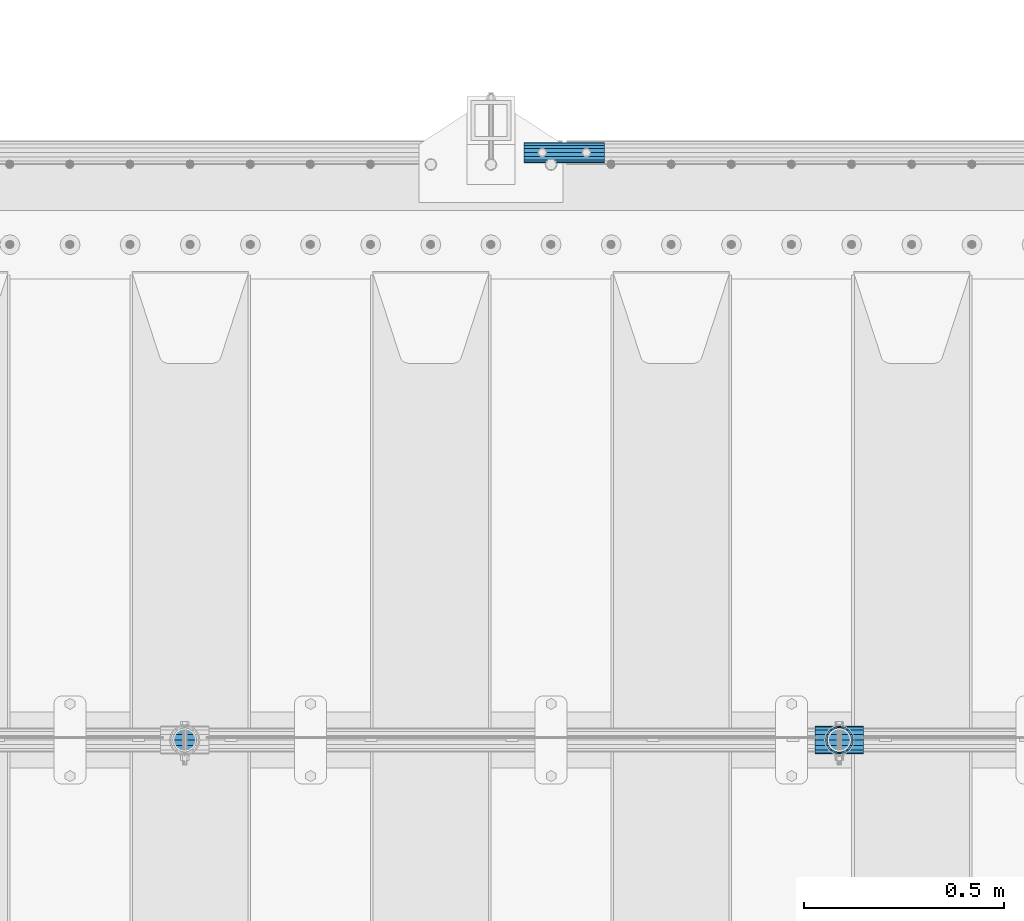
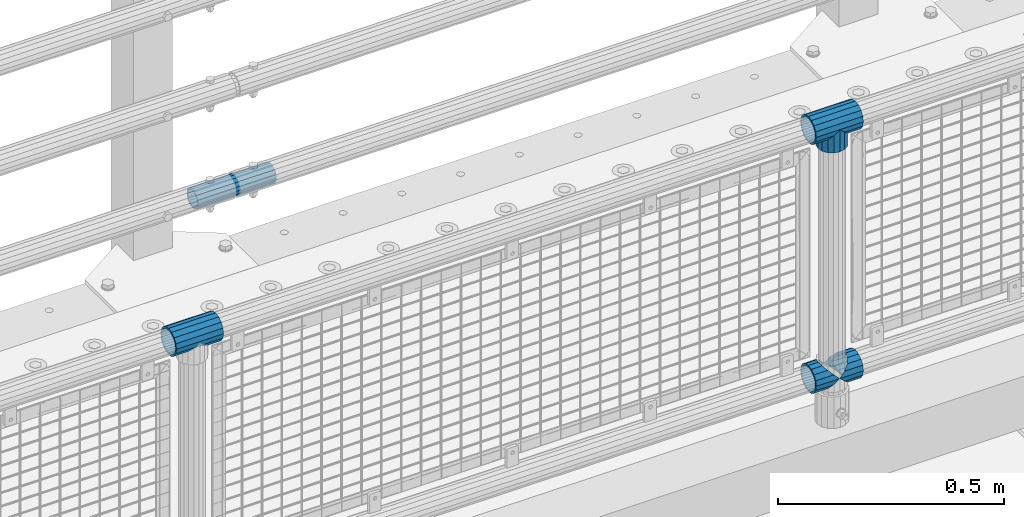
# One storey, part 167 of 270: 6 beams.
"""IFC2X3 building model written with IfcOpenShell, lengths in millimetres."""

from ifc_helpers import new_model, si_unit, frame, origin_with_axes, place, context, subcontext, project, spatial, faceted_brep, material, type_object, element, save


model = new_model("IFC2X3")

# Units and contexts
model_context = context("Model", 3, precision=1e-05, world=origin_with_axes())
body_context = subcontext(model_context, "Body", "Model", "MODEL_VIEW")
ifc_project = project(units=[si_unit("LENGTHUNIT", "METRE", prefix="MILLI"), si_unit("AREAUNIT", "SQUARE_METRE"), si_unit("VOLUMEUNIT", "CUBIC_METRE"), si_unit("MASSUNIT", "GRAM", prefix="KILO"), si_unit("TIMEUNIT", "SECOND"), si_unit("PLANEANGLEUNIT", "RADIAN"), si_unit("SOLIDANGLEUNIT", "STERADIAN"), si_unit("THERMODYNAMICTEMPERATUREUNIT", "DEGREE_CELSIUS"), si_unit("LUMINOUSINTENSITYUNIT", "LUMEN")], contexts=[model_context])

# Site, building, storey
site_placement = place(None, origin_with_axes())
site = spatial("IfcSite", under=ifc_project, at=site_placement, CompositionType="ELEMENT")
building_placement = place(site_placement, origin_with_axes())
building = spatial("IfcBuilding", under=site, at=building_placement, Name="Standard", CompositionType="ELEMENT")
storey_placement = place(building_placement, origin_with_axes())
storey = spatial("IfcBuildingStorey", under=building, at=storey_placement, Name="Undefined", CompositionType="ELEMENT", Elevation=0.0)

# Beams
ifc_material_1 = material(Name="Misc_Undefined")
beam_type_1 = type_object("IfcBeamType", PredefinedType="NOTDEFINED")
beam_1_placement = place(storey_placement, frame((10358.85, -16335.5, 298.17), z_axis=(0.0, 1.0, 0.0), x_axis=(1.0, 0.0, 0.0)))
element("IfcBeam", 1, at=beam_1_placement, inside=storey, type_object=beam_type_1, material=ifc_material_1, context=body_context, shape_type="Brep", body=[
    faceted_brep([(60.1499999999978, 0.0, -35.1499999999996), (46.698677352364, 13.4513226476329, -32.4743655677721), (46.698677352364, -13.4513226476329, -32.4743655677721), (33.0273231408937, 21.4606908090117, 21.4606908090118), (27.6756344322275, 26.8123795176776, 13.4513226476338), (27.6756344322275, 32.4743655677717, 13.4513226476338), (35.2951966412911, 24.8548033587072, 24.8548033587067), (35.2951966412911, 16.3810424080045, 24.8548033587067), (27.310256188277, 28.0397438117175, 11.6144421722802), (24.9999999999964, 30.35, 0.0), (24.9999999999964, 35.15, 0.0), (27.6756344322275, 26.8123795176775, -13.4513226476338), (27.6756344322275, 32.4743655677717, -13.4513226476338), (27.310256188277, 28.0397438117175, -11.6144421722802), (35.2951966412911, 16.3810424080045, -24.8548033587067), (35.2951966412911, 24.8548033587072, -24.8548033587067), (33.0273231408937, 21.4606908090117, -21.4606908090118), (40.0617968770166, 11.6144421722805, -28.0397438117179), (43.519339601633, 0.0, -30.3500000000004), (40.0617968770166, -11.6144421722805, -28.0397438117179), (35.2951966412911, -16.3810424080045, -24.8548033587067), (35.2951966412911, -24.8548033587072, -24.8548033587067), (33.0273231408937, -21.4606908090117, -21.4606908090118), (27.6756344322275, -26.8123795176776, -13.4513226476338), (27.6756344322275, -32.4743655677717, -13.4513226476338), (27.310256188277, -28.0397438117175, -11.6144421722802), (24.9999999999964, -30.35, 0.0), (24.9999999999964, -35.15, 0.0), (27.310256188277, -28.0397438117175, 11.6144421722802), (27.6756344322275, -26.8123795176775, 13.4513226476338), (27.6756344322275, -32.4743655677717, 13.4513226476338), (33.0273231408937, -21.4606908090117, 21.4606908090118), (35.2951966412911, -16.3810424080078, 24.8548033587067), (35.2951966412911, -24.8548033587072, 24.8548033587067), (60.1499999999978, 0.0, 35.1499999999996), (46.698677352364, -13.4513226476329, 32.4743655677721), (46.698677352364, 13.4513226476329, 32.4743655677721), (40.061796877013, -11.6144421722805, 28.0397438117179), (43.5193396016293, 0.0, 30.3500000000004), (40.061796877013, 11.6144421722805, 28.0397438117179), (0.0, -32.4743655677721, -13.4513226476338), (0.0, -24.8548033587067, -24.8548033587067), (0.0, -13.4513226476338, -32.4743655677703), (0.0, 0.0, -35.1499999999996), (0.0, 13.4513226476338, -32.4743655677703), (0.0, 24.8548033587067, -24.8548033587067), (0.0, 32.4743655677721, -13.4513226476338), (0.0, 35.1499999999996, 0.0), (0.0, 32.4743655677721, 13.4513226476338), (0.0, 24.8548033587067, 24.8548033587067), (0.0, 13.4513226476338, 32.4743655677703), (0.0, 0.0, 35.1499999999996), (0.0, -32.4743655677721, 13.4513226476338), (0.0, -35.1499999999996, 0.0), (0.0, -24.8548033587067, 24.8548033587067), (0.0, -13.4513226476338, 32.4743655677703), (0.0, -28.0397438117179, -11.614442172282), (0.0, -21.4606908090118, -21.46069080901), (0.0, -11.6144421722802, -28.0397438117179), (0.0, 0.0, -30.3499999999985), (0.0, 11.6144421722802, -28.0397438117179), (0.0, 21.4606908090118, -21.46069080901), (0.0, 28.0397438117179, -11.614442172282), (0.0, 30.3500000000004, 0.0), (0.0, 28.0397438117179, 11.614442172282), (0.0, 21.4606908090118, 21.46069080901), (0.0, 11.6144421722802, 28.0397438117179), (0.0, 0.0, 30.3499999999985), (0.0, -11.6144421722802, 28.0397438117179), (0.0, -21.4606908090118, 21.46069080901), (0.0, -28.0397438117179, 11.614442172282), (0.0, -30.3500000000004, 0.0)], [[[0, 1, 2]], [[3, 4, 5, 6, 7]], [[8, 9, 10, 5, 4]], [[11, 12, 10, 9, 13]], [[14, 15, 12, 11, 16]], [[2, 1, 15, 14, 17, 18, 19, 20, 21]], [[21, 20, 22, 23, 24]], [[24, 23, 25, 26, 27]], [[27, 26, 28, 29, 30]], [[30, 29, 31, 32, 33]], [[34, 35, 36]], [[33, 32, 37, 38, 39, 7, 6, 36, 35]], [[40, 41, 21, 24]], [[41, 42, 2, 21]], [[42, 43, 0, 2]], [[43, 44, 1, 0]], [[44, 45, 15, 1]], [[45, 46, 12, 15]], [[46, 47, 10, 12]], [[47, 48, 5, 10]], [[48, 49, 6, 5]], [[49, 50, 36, 6]], [[50, 51, 34, 36]], [[52, 53, 27, 30]], [[54, 52, 30, 33]], [[55, 54, 33, 35]], [[51, 55, 35, 34]], [[53, 40, 24, 27]], [[52, 54, 55, 51, 50, 49, 48, 47, 46, 45, 44, 43, 42, 41, 40, 53], [56, 57, 58, 59, 60, 61, 62, 63, 64, 65, 66, 67, 68, 69, 70, 71]], [[68, 67, 38, 37]], [[31, 69, 68, 37, 32]], [[28, 70, 69, 31, 29]], [[71, 70, 28, 26]], [[56, 71, 26, 25]], [[57, 56, 25, 23, 22]], [[58, 57, 22, 20, 19]], [[59, 58, 19, 18]], [[60, 59, 18, 17]], [[16, 61, 60, 17, 14]], [[13, 62, 61, 16, 11]], [[63, 62, 13, 9]], [[64, 63, 9, 8]], [[65, 64, 8, 4, 3]], [[66, 65, 3, 7, 39]], [[67, 66, 39, 38]]]),
])
beam_2_placement = place(storey_placement, frame((10419.0, -16335.5, 298.17), z_axis=(0.0, 1.0, 0.0), x_axis=(1.0, 0.0, 0.0)))
element("IfcBeam", 2, at=beam_2_placement, inside=storey, type_object=beam_type_1, material=ifc_material_1, context=body_context, shape_type="Brep", body=[
    faceted_brep([(13.4513226476338, 13.4513226476329, 32.4743655677721), (13.4513226476338, -13.4513226476329, 32.4743655677721), (0.0, 0.0, 35.1499999999996), (27.1226768591041, -21.4606908090117, -21.4606908090118), (24.8548033587067, -16.3810424080045, -24.8548033587067), (24.8548033587067, -24.8548033587072, -24.8548033587067), (32.4743655677703, -32.4743655677717, -13.4513226476338), (32.4743655677703, -26.8123795176776, -13.4513226476338), (0.0, 0.0, -35.1499999999996), (13.4513226476338, -13.4513226476329, -32.4743655677721), (13.4513226476338, 13.4513226476329, -32.4743655677721), (20.0882031229849, -11.6144421722805, -28.0397438117179), (16.6306603983721, 0.0, -30.3500000000004), (20.0882031229849, 11.6144421722805, -28.0397438117179), (24.8548033587067, 16.3810424080045, -24.8548033587067), (24.8548033587067, 24.8548033587072, -24.8548033587067), (27.1226768591041, 21.4606908090117, -21.4606908090118), (32.4743655677703, 26.8123795176775, -13.4513226476338), (32.4743655677703, 32.4743655677717, -13.4513226476338), (32.8397438117172, 28.0397438117175, -11.6144421722802), (35.1500000000015, 30.35, 0.0), (35.1500000000015, 35.1500000000003, 0.0), (32.8397438117208, 28.0397438117175, 11.6144421722802), (32.4743655677703, 26.8123795176776, 13.4513226476338), (32.4743655677703, 32.4743655677717, 13.4513226476338), (27.1226768591041, 21.4606908090117, 21.4606908090118), (24.8548033587067, 16.3810424080045, 24.8548033587067), (24.8548033587067, 24.8548033587072, 24.8548033587067), (20.0882031229812, 11.6144421722805, 28.0397438117179), (16.6306603983612, 0.0, 30.3500000000004), (20.0882031229812, -11.6144421722805, 28.0397438117179), (24.8548033587067, -16.3810424080045, 24.8548033587067), (24.8548033587067, -24.8548033587072, 24.8548033587067), (32.4743655677703, -26.8123795176775, 13.4513226476338), (32.4743655677703, -32.4743655677717, 13.4513226476338), (27.1226768591041, -21.4606908090117, 21.4606908090118), (35.1500000000015, -30.35, 0.0), (35.1500000000015, -35.15, 0.0), (32.8397438117208, -28.0397438117175, 11.6144421722802), (32.8397438117172, -28.0397438117175, -11.6144421722802), (60.1500000000015, -24.8548033587072, -24.8548033587067), (60.1500000000015, -32.4743655677717, -13.4513226476338), (60.1500000000015, -13.4513226476329, -32.4743655677721), (60.1499999999978, 0.0, -35.1499999999996), (60.1500000000015, 13.4513226476329, -32.4743655677721), (60.1500000000015, 24.8548033587072, -24.8548033587067), (60.1500000000015, 32.4743655677717, -13.4513226476338), (60.1500000000015, 35.15, 0.0), (60.1500000000015, 32.4743655677717, 13.4513226476338), (60.1500000000015, 24.8548033587072, 24.8548033587067), (60.1500000000015, 13.4513226476329, 32.4743655677721), (60.1499999999978, 0.0, 35.1499999999996), (60.1500000000015, -13.4513226476329, 32.4743655677721), (60.1500000000015, -24.8548033587072, 24.8548033587067), (60.1500000000015, -32.4743655677717, 13.4513226476338), (60.1500000000015, -35.15, 0.0), (60.1500000000015, -21.4606908090117, 21.4606908090118), (60.1500000000015, -11.6144421722805, 28.0397438117179), (60.1500000000015, 0.0, 30.3500000000004), (60.1500000000015, 11.6144421722805, 28.0397438117179), (60.1500000000015, 21.4606908090117, 21.4606908090118), (60.1500000000015, 28.0397438117175, 11.6144421722802), (60.1500000000015, 30.35, 0.0), (60.1500000000015, 28.0397438117175, -11.6144421722802), (60.1500000000015, 21.4606908090117, -21.4606908090118), (60.1500000000015, 11.6144421722805, -28.0397438117179), (60.1500000000015, 0.0, -30.3500000000004), (60.1500000000015, -11.6144421722805, -28.0397438117179), (60.1500000000015, -21.4606908090117, -21.4606908090118), (60.1500000000015, -28.0397438117175, -11.6144421722802), (60.1500000000015, -30.35, 0.0), (60.1500000000015, -28.0397438117175, 11.6144421722802)], [[[0, 1, 2]], [[3, 4, 5, 6, 7]], [[8, 9, 10]], [[10, 9, 5, 4, 11, 12, 13, 14, 15]], [[15, 14, 16, 17, 18]], [[18, 17, 19, 20, 21]], [[21, 20, 22, 23, 24]], [[24, 23, 25, 26, 27]], [[27, 26, 28, 29, 30, 31, 32, 1, 0]], [[33, 34, 32, 31, 35]], [[36, 37, 34, 33, 38]], [[39, 7, 6, 37, 36]], [[40, 41, 6, 5]], [[42, 40, 5, 9]], [[43, 42, 9, 8]], [[44, 43, 8, 10]], [[45, 44, 10, 15]], [[46, 45, 15, 18]], [[47, 46, 18, 21]], [[48, 47, 21, 24]], [[49, 48, 24, 27]], [[50, 49, 27, 0]], [[51, 50, 0, 2]], [[52, 51, 2, 1]], [[53, 52, 1, 32]], [[54, 53, 32, 34]], [[55, 54, 34, 37]], [[41, 55, 37, 6]], [[40, 42, 43, 44, 45, 46, 47, 48, 49, 50, 51, 52, 53, 54, 55, 41], [56, 57, 58, 59, 60, 61, 62, 63, 64, 65, 66, 67, 68, 69, 70, 71]], [[71, 70, 36, 38]], [[35, 56, 71, 38, 33]], [[30, 57, 56, 35, 31]], [[58, 57, 30, 29]], [[59, 58, 29, 28]], [[60, 59, 28, 26, 25]], [[61, 60, 25, 23, 22]], [[62, 61, 22, 20]], [[63, 62, 20, 19]], [[16, 64, 63, 19, 17]], [[13, 65, 64, 16, 14]], [[66, 65, 13, 12]], [[67, 66, 12, 11]], [[68, 67, 11, 4, 3]], [[69, 68, 3, 7, 39]], [[70, 69, 39, 36]]]),
])
beam_3_placement = place(storey_placement, frame((8725.85, -16335.5, 969.849999999999), z_axis=(0.0, 0.0, 1.0), x_axis=(1.0, 0.0, 0.0)))
element("IfcBeam", 3, at=beam_3_placement, inside=storey, type_object=beam_type_1, material=ifc_material_1, context=body_context, shape_type="Brep", body=[
    faceted_brep([(88.1897438117176, -11.6144421722802, -28.0397438117176), (88.1897438117176, -11.6144421722802, -32.839743811718), (86.9623795176758, -13.4513226476338, -32.4743655677718), (81.6106908090119, -21.4606908090118, -27.1226768591079), (81.6106908090119, -21.4606908090118, -21.4606908090117), (76.5310424080044, -24.8548033587067, -24.8548033587072), (71.7644421722807, -28.0397438117179, -20.0882031229829), (71.7644421722807, -28.0397438117179, -11.6144421722805), (60.1500000000001, -30.3500000000004, -16.6306603983638), (60.1500000000015, -30.35, 0.0), (48.5355578277195, -28.0397438117179, -20.0882031229829), (48.5355578277195, -28.0397438117179, -11.6144421722805), (43.7689575919958, -24.8548033587067, -24.8548033587072), (38.6893091909883, -21.4606908090118, -27.1226768591079), (38.6893091909883, -21.4606908090118, -21.4606908090117), (33.3376204823235, -13.4513226476338, -32.4743655677718), (32.1102561882826, -11.6144421722802, -32.839743811718), (32.1102561882826, -11.6144421722802, -28.0397438117176), (29.8000000000002, 0.0, -35.15), (29.8000000000002, 0.0, -30.35), (32.1102561882826, 11.6144421722802, -32.839743811718), (32.1102561882826, 11.6144421722802, -28.0397438117176), (33.3376204823244, 13.4513226476338, -32.4743655677718), (38.6893091909883, 21.4606908090118, -27.1226768591056), (38.6893091909883, 21.4606908090118, -21.4606908090117), (43.7689575919958, 24.8548033587067, -24.8548033587072), (48.5355578277195, 28.0397438117179, -20.0882031229829), (48.5355578277195, 28.0397438117179, -11.6144421722805), (60.1500000000001, 30.3500000000004, -16.6306603983638), (60.1500000000015, 30.35, 0.0), (71.7644421722807, 28.0397438117179, -20.0882031229829), (71.7644421722807, 28.0397438117179, -11.6144421722805), (76.5310424080044, 24.8548033587067, -24.8548033587072), (81.6106908090119, 21.4606908090118, -27.1226768591056), (81.6106908090119, 21.4606908090118, -21.4606908090117), (86.9623795176776, 13.4513226476338, -32.4743655677718), (88.1897438117176, 11.6144421722802, -32.839743811718), (88.1897438117176, 11.6144421722802, -28.0397438117176), (90.5, 0.0, -35.15), (90.5, 0.0, -30.35), (0.0, -21.4606908090118, -21.46069080901), (0.0, -28.0397438117179, -11.614442172282), (0.0, -11.6144421722802, -28.0397438117179), (0.0, 0.0, -30.3499999999985), (0.0, 11.6144421722802, -28.0397438117179), (0.0, 21.4606908090118, -21.46069080901), (0.0, 28.0397438117179, -11.614442172282), (0.0, 30.3500000000004, 0.0), (0.0, 32.4743655677721, -13.4513226476338), (0.0, 35.1499999999996, 0.0), (120.3, 35.1499999999996, 0.0), (120.3, 32.4743655677721, -13.4513226476329), (0.0, 32.4743655677721, 13.4513226476338), (120.3, 32.4743655677721, 13.4513226476329), (0.0, 24.8548033587067, 24.8548033587067), (120.3, 24.8548033587067, 24.8548033587072), (0.0, 13.4513226476338, 32.4743655677703), (120.3, 13.4513226476338, 32.4743655677718), (0.0, 0.0, 35.1499999999996), (120.3, 0.0, 35.15), (0.0, -13.4513226476338, 32.4743655677703), (120.3, -13.4513226476338, 32.4743655677718), (0.0, -24.8548033587067, 24.8548033587067), (120.3, -24.8548033587067, 24.8548033587072), (0.0, -32.4743655677721, 13.4513226476338), (120.3, -32.4743655677721, 13.4513226476329), (0.0, -35.1499999999996, 0.0), (120.3, -35.1499999999996, 0.0), (0.0, -32.4743655677721, -13.4513226476338), (120.3, -32.4743655677721, -13.4513226476329), (0.0, 24.8548033587067, -24.8548033587067), (0.0, 13.4513226476338, -32.4743655677703), (0.0, 0.0, -35.1499999999996), (0.0, -13.4513226476338, -32.4743655677703), (0.0, -24.8548033587067, -24.8548033587067), (0.0, 28.0397438117179, 11.614442172282), (0.0, 21.4606908090118, 21.46069080901), (0.0, 11.6144421722802, 28.0397438117179), (0.0, 0.0, 30.3499999999985), (0.0, -11.6144421722802, 28.0397438117179), (0.0, -21.4606908090118, 21.46069080901), (0.0, -28.0397438117179, 11.614442172282), (0.0, -30.3500000000004, 0.0), (120.3, -30.3500000000004, 0.0), (120.3, -28.0397438117179, -11.6144421722805), (120.3, -21.4606908090118, -21.4606908090117), (120.3, -11.6144421722802, -28.0397438117176), (120.3, 0.0, -30.35), (120.3, 21.4606908090118, -21.4606908090117), (120.3, 28.0397438117179, -11.6144421722805), (120.3, 11.6144421722802, -28.0397438117176), (120.3, 30.3500000000004, 0.0), (120.3, 28.0397438117179, 11.6144421722805), (120.3, 21.4606908090118, 21.4606908090117), (120.3, 11.6144421722802, 28.0397438117176), (120.3, 0.0, 30.35), (120.3, -11.6144421722802, 28.0397438117176), (120.3, -21.4606908090118, 21.4606908090117), (120.3, -28.0397438117179, 11.6144421722805), (120.3, -24.8548033587067, -24.8548033587072), (120.3, -13.4513226476338, -32.4743655677718), (120.3, 0.0, -35.15), (120.3, 13.4513226476338, -32.4743655677718), (120.3, 24.8548033587067, -24.8548033587072)], [[[0, 1, 2, 3, 4]], [[4, 3, 5, 6, 7]], [[7, 6, 8, 9]], [[9, 8, 10, 11]], [[11, 10, 12, 13, 14]], [[14, 13, 15, 16, 17]], [[17, 16, 18, 19]], [[19, 18, 20, 21]], [[21, 20, 22, 23, 24]], [[24, 23, 25, 26, 27]], [[27, 26, 28, 29]], [[29, 28, 30, 31]], [[31, 30, 32, 33, 34]], [[34, 33, 35, 36, 37]], [[37, 36, 38, 39]], [[39, 38, 1, 0]], [[40, 41, 11, 14]], [[42, 40, 14, 17]], [[43, 42, 17, 19]], [[44, 43, 19, 21]], [[45, 44, 21, 24]], [[46, 45, 24, 27]], [[47, 46, 27, 29]], [[48, 49, 50, 51]], [[49, 52, 53, 50]], [[52, 54, 55, 53]], [[54, 56, 57, 55]], [[56, 58, 59, 57]], [[58, 60, 61, 59]], [[60, 62, 63, 61]], [[62, 64, 65, 63]], [[64, 66, 67, 65]], [[66, 68, 69, 67]], [[64, 62, 60, 58, 56, 54, 52, 49, 48, 70, 71, 72, 73, 74, 68, 66], [41, 40, 42, 43, 44, 45, 46, 47, 75, 76, 77, 78, 79, 80, 81, 82]], [[41, 82, 9, 11]], [[83, 84, 7, 9]], [[84, 85, 4, 7]], [[85, 86, 0, 4]], [[86, 87, 39, 0]], [[88, 89, 31, 34]], [[90, 88, 34, 37]], [[87, 90, 37, 39]], [[89, 91, 29, 31]], [[75, 47, 29, 91, 92]], [[76, 75, 92, 93]], [[77, 76, 93, 94]], [[78, 77, 94, 95]], [[79, 78, 95, 96]], [[80, 79, 96, 97]], [[81, 80, 97, 98]], [[9, 82, 81, 98, 83]], [[99, 100, 101, 102, 103, 51, 50, 53, 55, 57, 59, 61, 63, 65, 67, 69], [97, 96, 95, 94, 93, 92, 91, 89, 88, 90, 87, 86, 85, 84, 83, 98]], [[35, 102, 101, 38, 36]], [[32, 103, 102, 35, 33]], [[28, 26, 25, 70, 48, 51, 103, 32, 30]], [[22, 71, 70, 25, 23]], [[18, 72, 71, 22, 20]], [[73, 72, 18, 16, 15]], [[74, 73, 15, 13, 12]], [[99, 69, 68, 74, 12, 10, 8, 6, 5]], [[100, 99, 5, 3, 2]], [[101, 100, 2, 1, 38]]]),
])
beam_4_placement = place(storey_placement, frame((10419.0, -16335.5, 969.849999999999), z_axis=(0.0, 1.0, 0.0), x_axis=(0.0, 0.0, -1.0)))
element("IfcBeam", 4, at=beam_4_placement, inside=storey, type_object=beam_type_1, material=ifc_material_1, context=body_context, shape_type="Brep", body=[
    faceted_brep([(13.4513226476338, 13.4513226476329, 32.4743655677721), (13.4513226476338, -13.4513226476329, 32.4743655677721), (0.0, 0.0, 35.1499999999996), (27.1226768591041, -21.4606908090117, -21.4606908090118), (24.8548033587067, -16.3810424080045, -24.8548033587067), (24.8548033587067, -24.8548033587072, -24.8548033587067), (32.4743655677703, -32.4743655677717, -13.4513226476338), (32.4743655677703, -26.8123795176776, -13.4513226476338), (0.0, 0.0, -35.1499999999996), (13.4513226476338, -13.4513226476329, -32.4743655677721), (13.4513226476338, 13.4513226476329, -32.4743655677721), (20.0882031229849, -11.6144421722805, -28.0397438117179), (16.6306603983721, 0.0, -30.3500000000004), (20.0882031229849, 11.6144421722805, -28.0397438117179), (24.8548033587067, 16.3810424080045, -24.8548033587067), (24.8548033587067, 24.8548033587072, -24.8548033587067), (27.1226768591041, 21.4606908090117, -21.4606908090118), (32.4743655677703, 26.8123795176775, -13.4513226476338), (32.4743655677703, 32.4743655677717, -13.4513226476338), (32.8397438117172, 28.0397438117175, -11.6144421722802), (35.1500000000015, 30.35, 0.0), (35.1500000000015, 35.1500000000003, 0.0), (32.8397438117208, 28.0397438117175, 11.6144421722802), (32.4743655677703, 26.8123795176776, 13.4513226476338), (32.4743655677703, 32.4743655677717, 13.4513226476338), (27.1226768591041, 21.4606908090117, 21.4606908090118), (24.8548033587067, 16.3810424080045, 24.8548033587067), (24.8548033587067, 24.8548033587072, 24.8548033587067), (20.0882031229812, 11.6144421722805, 28.0397438117179), (16.6306603983612, 0.0, 30.3500000000004), (20.0882031229812, -11.6144421722805, 28.0397438117179), (24.8548033587067, -16.3810424080045, 24.8548033587067), (24.8548033587067, -24.8548033587072, 24.8548033587067), (32.4743655677703, -26.8123795176775, 13.4513226476338), (32.4743655677703, -32.4743655677717, 13.4513226476338), (27.1226768591041, -21.4606908090117, 21.4606908090118), (35.1500000000015, -30.35, 0.0), (35.1500000000015, -35.15, 0.0), (32.8397438117208, -28.0397438117175, 11.6144421722802), (32.8397438117172, -28.0397438117175, -11.6144421722802), (60.1500000000015, -24.8548033587072, -24.8548033587067), (60.1500000000015, -32.4743655677717, -13.4513226476338), (60.1500000000015, -13.4513226476329, -32.4743655677721), (60.1499999999978, 0.0, -35.1499999999996), (60.1500000000015, 13.4513226476329, -32.4743655677721), (60.1500000000015, 24.8548033587072, -24.8548033587067), (60.1500000000015, 32.4743655677717, -13.4513226476338), (60.1500000000015, 35.15, 0.0), (60.1500000000015, 32.4743655677717, 13.4513226476338), (60.1500000000015, 24.8548033587072, 24.8548033587067), (60.1500000000015, 13.4513226476329, 32.4743655677721), (60.1499999999978, 0.0, 35.1499999999996), (60.1500000000015, -13.4513226476329, 32.4743655677721), (60.1500000000015, -24.8548033587072, 24.8548033587067), (60.1500000000015, -32.4743655677717, 13.4513226476338), (60.1500000000015, -35.15, 0.0), (60.1500000000015, -21.4606908090117, 21.4606908090118), (60.1500000000015, -11.6144421722805, 28.0397438117179), (60.1500000000015, 0.0, 30.3500000000004), (60.1500000000015, 11.6144421722805, 28.0397438117179), (60.1500000000015, 21.4606908090117, 21.4606908090118), (60.1500000000015, 28.0397438117175, 11.6144421722802), (60.1500000000015, 30.35, 0.0), (60.1500000000015, 28.0397438117175, -11.6144421722802), (60.1500000000015, 21.4606908090117, -21.4606908090118), (60.1500000000015, 11.6144421722805, -28.0397438117179), (60.1500000000015, 0.0, -30.3500000000004), (60.1500000000015, -11.6144421722805, -28.0397438117179), (60.1500000000015, -21.4606908090117, -21.4606908090118), (60.1500000000015, -28.0397438117175, -11.6144421722802), (60.1500000000015, -30.35, 0.0), (60.1500000000015, -28.0397438117175, 11.6144421722802)], [[[0, 1, 2]], [[3, 4, 5, 6, 7]], [[8, 9, 10]], [[10, 9, 5, 4, 11, 12, 13, 14, 15]], [[15, 14, 16, 17, 18]], [[18, 17, 19, 20, 21]], [[21, 20, 22, 23, 24]], [[24, 23, 25, 26, 27]], [[27, 26, 28, 29, 30, 31, 32, 1, 0]], [[33, 34, 32, 31, 35]], [[36, 37, 34, 33, 38]], [[39, 7, 6, 37, 36]], [[40, 41, 6, 5]], [[42, 40, 5, 9]], [[43, 42, 9, 8]], [[44, 43, 8, 10]], [[45, 44, 10, 15]], [[46, 45, 15, 18]], [[47, 46, 18, 21]], [[48, 47, 21, 24]], [[49, 48, 24, 27]], [[50, 49, 27, 0]], [[51, 50, 0, 2]], [[52, 51, 2, 1]], [[53, 52, 1, 32]], [[54, 53, 32, 34]], [[55, 54, 34, 37]], [[41, 55, 37, 6]], [[40, 42, 43, 44, 45, 46, 47, 48, 49, 50, 51, 52, 53, 54, 55, 41], [56, 57, 58, 59, 60, 61, 62, 63, 64, 65, 66, 67, 68, 69, 70, 71]], [[71, 70, 36, 38]], [[35, 56, 71, 38, 33]], [[30, 57, 56, 35, 31]], [[58, 57, 30, 29]], [[59, 58, 29, 28]], [[60, 59, 28, 26, 25]], [[61, 60, 25, 23, 22]], [[62, 61, 22, 20]], [[63, 62, 20, 19]], [[16, 64, 63, 19, 17]], [[13, 65, 64, 16, 14]], [[66, 65, 13, 12]], [[67, 66, 12, 11]], [[68, 67, 11, 4, 3]], [[69, 68, 3, 7, 39]], [[70, 69, 39, 36]]]),
])
beam_5_placement = place(storey_placement, frame((10358.85, -16335.5, 969.849999999999), z_axis=(0.0, 0.0, 1.0), x_axis=(1.0, 0.0, 0.0)))
element("IfcBeam", 5, at=beam_5_placement, inside=storey, type_object=beam_type_1, material=ifc_material_1, context=body_context, shape_type="Brep", body=[
    faceted_brep([(88.1897438117176, -11.6144421722802, -28.0397438117176), (88.1897438117176, -11.6144421722802, -32.839743811718), (86.9623795176758, -13.4513226476338, -32.4743655677718), (81.6106908090119, -21.4606908090118, -27.1226768591079), (81.6106908090119, -21.4606908090118, -21.4606908090117), (76.5310424080044, -24.8548033587067, -24.8548033587072), (71.7644421722807, -28.0397438117179, -20.0882031229829), (71.7644421722807, -28.0397438117179, -11.6144421722805), (60.1500000000001, -30.3500000000004, -16.6306603983638), (60.1500000000015, -30.35, 0.0), (48.5355578277195, -28.0397438117179, -20.0882031229829), (48.5355578277195, -28.0397438117179, -11.6144421722805), (43.7689575919958, -24.8548033587067, -24.8548033587072), (38.6893091909883, -21.4606908090118, -27.1226768591079), (38.6893091909883, -21.4606908090118, -21.4606908090117), (33.3376204823235, -13.4513226476338, -32.4743655677718), (32.1102561882826, -11.6144421722802, -32.839743811718), (32.1102561882826, -11.6144421722802, -28.0397438117176), (29.8000000000002, 0.0, -35.15), (29.8000000000002, 0.0, -30.35), (32.1102561882826, 11.6144421722802, -32.839743811718), (32.1102561882826, 11.6144421722802, -28.0397438117176), (33.3376204823244, 13.4513226476338, -32.4743655677718), (38.6893091909883, 21.4606908090118, -27.1226768591056), (38.6893091909883, 21.4606908090118, -21.4606908090117), (43.7689575919958, 24.8548033587067, -24.8548033587072), (48.5355578277195, 28.0397438117179, -20.0882031229829), (48.5355578277195, 28.0397438117179, -11.6144421722805), (60.1500000000001, 30.3500000000004, -16.6306603983638), (60.1500000000015, 30.35, 0.0), (71.7644421722807, 28.0397438117179, -20.0882031229829), (71.7644421722807, 28.0397438117179, -11.6144421722805), (76.5310424080044, 24.8548033587067, -24.8548033587072), (81.6106908090119, 21.4606908090118, -27.1226768591056), (81.6106908090119, 21.4606908090118, -21.4606908090117), (86.9623795176776, 13.4513226476338, -32.4743655677718), (88.1897438117176, 11.6144421722802, -32.839743811718), (88.1897438117176, 11.6144421722802, -28.0397438117176), (90.5, 0.0, -35.15), (90.5, 0.0, -30.35), (0.0, -21.4606908090118, -21.46069080901), (0.0, -28.0397438117179, -11.614442172282), (0.0, -11.6144421722802, -28.0397438117179), (0.0, 0.0, -30.3499999999985), (0.0, 11.6144421722802, -28.0397438117179), (0.0, 21.4606908090118, -21.46069080901), (0.0, 28.0397438117179, -11.614442172282), (0.0, 30.3500000000004, 0.0), (0.0, 32.4743655677721, -13.4513226476338), (0.0, 35.1499999999996, 0.0), (120.3, 35.1499999999996, 0.0), (120.3, 32.4743655677721, -13.4513226476329), (0.0, 32.4743655677721, 13.4513226476338), (120.3, 32.4743655677721, 13.4513226476329), (0.0, 24.8548033587067, 24.8548033587067), (120.3, 24.8548033587067, 24.8548033587072), (0.0, 13.4513226476338, 32.4743655677703), (120.3, 13.4513226476338, 32.4743655677718), (0.0, 0.0, 35.1499999999996), (120.3, 0.0, 35.15), (0.0, -13.4513226476338, 32.4743655677703), (120.3, -13.4513226476338, 32.4743655677718), (0.0, -24.8548033587067, 24.8548033587067), (120.3, -24.8548033587067, 24.8548033587072), (0.0, -32.4743655677721, 13.4513226476338), (120.3, -32.4743655677721, 13.4513226476329), (0.0, -35.1499999999996, 0.0), (120.3, -35.1499999999996, 0.0), (0.0, -32.4743655677721, -13.4513226476338), (120.3, -32.4743655677721, -13.4513226476329), (0.0, 24.8548033587067, -24.8548033587067), (0.0, 13.4513226476338, -32.4743655677703), (0.0, 0.0, -35.1499999999996), (0.0, -13.4513226476338, -32.4743655677703), (0.0, -24.8548033587067, -24.8548033587067), (0.0, 28.0397438117179, 11.614442172282), (0.0, 21.4606908090118, 21.46069080901), (0.0, 11.6144421722802, 28.0397438117179), (0.0, 0.0, 30.3499999999985), (0.0, -11.6144421722802, 28.0397438117179), (0.0, -21.4606908090118, 21.46069080901), (0.0, -28.0397438117179, 11.614442172282), (0.0, -30.3500000000004, 0.0), (120.3, -30.3500000000004, 0.0), (120.3, -28.0397438117179, -11.6144421722805), (120.3, -21.4606908090118, -21.4606908090117), (120.3, -11.6144421722802, -28.0397438117176), (120.3, 0.0, -30.35), (120.3, 21.4606908090118, -21.4606908090117), (120.3, 28.0397438117179, -11.6144421722805), (120.3, 11.6144421722802, -28.0397438117176), (120.3, 30.3500000000004, 0.0), (120.3, 28.0397438117179, 11.6144421722805), (120.3, 21.4606908090118, 21.4606908090117), (120.3, 11.6144421722802, 28.0397438117176), (120.3, 0.0, 30.35), (120.3, -11.6144421722802, 28.0397438117176), (120.3, -21.4606908090118, 21.4606908090117), (120.3, -28.0397438117179, 11.6144421722805), (120.3, -24.8548033587067, -24.8548033587072), (120.3, -13.4513226476338, -32.4743655677718), (120.3, 0.0, -35.15), (120.3, 13.4513226476338, -32.4743655677718), (120.3, 24.8548033587067, -24.8548033587072)], [[[0, 1, 2, 3, 4]], [[4, 3, 5, 6, 7]], [[7, 6, 8, 9]], [[9, 8, 10, 11]], [[11, 10, 12, 13, 14]], [[14, 13, 15, 16, 17]], [[17, 16, 18, 19]], [[19, 18, 20, 21]], [[21, 20, 22, 23, 24]], [[24, 23, 25, 26, 27]], [[27, 26, 28, 29]], [[29, 28, 30, 31]], [[31, 30, 32, 33, 34]], [[34, 33, 35, 36, 37]], [[37, 36, 38, 39]], [[39, 38, 1, 0]], [[40, 41, 11, 14]], [[42, 40, 14, 17]], [[43, 42, 17, 19]], [[44, 43, 19, 21]], [[45, 44, 21, 24]], [[46, 45, 24, 27]], [[47, 46, 27, 29]], [[48, 49, 50, 51]], [[49, 52, 53, 50]], [[52, 54, 55, 53]], [[54, 56, 57, 55]], [[56, 58, 59, 57]], [[58, 60, 61, 59]], [[60, 62, 63, 61]], [[62, 64, 65, 63]], [[64, 66, 67, 65]], [[66, 68, 69, 67]], [[64, 62, 60, 58, 56, 54, 52, 49, 48, 70, 71, 72, 73, 74, 68, 66], [41, 40, 42, 43, 44, 45, 46, 47, 75, 76, 77, 78, 79, 80, 81, 82]], [[41, 82, 9, 11]], [[83, 84, 7, 9]], [[84, 85, 4, 7]], [[85, 86, 0, 4]], [[86, 87, 39, 0]], [[88, 89, 31, 34]], [[90, 88, 34, 37]], [[87, 90, 37, 39]], [[89, 91, 29, 31]], [[75, 47, 29, 91, 92]], [[76, 75, 92, 93]], [[77, 76, 93, 94]], [[78, 77, 94, 95]], [[79, 78, 95, 96]], [[80, 79, 96, 97]], [[81, 80, 97, 98]], [[9, 82, 81, 98, 83]], [[99, 100, 101, 102, 103, 51, 50, 53, 55, 57, 59, 61, 63, 65, 67, 69], [97, 96, 95, 94, 93, 92, 91, 89, 88, 90, 87, 86, 85, 84, 83, 98]], [[35, 102, 101, 38, 36]], [[32, 103, 102, 35, 33]], [[28, 26, 25, 70, 48, 51, 103, 32, 30]], [[22, 71, 70, 25, 23]], [[18, 72, 71, 22, 20]], [[73, 72, 18, 16, 15]], [[74, 73, 15, 13, 12]], [[99, 69, 68, 74, 12, 10, 8, 6, 5]], [[100, 99, 5, 3, 2]], [[101, 100, 2, 1, 38]]]),
])
ifc_material_2 = material()
beam_type_2 = type_object("IfcBeamType", PredefinedType="NOTDEFINED")
beam_6_placement = place(storey_placement, frame((9632.99750299995, -14870.1499999996, 149.849999999726), z_axis=(0.0, 0.0, 1.0), x_axis=(1.0, 0.0, 0.0)))
element("IfcBeam", 6, at=beam_6_placement, inside=storey, type_object=beam_type_2, material=ifc_material_2, context=body_context, shape_type="Brep", body=[
    faceted_brep([(0.0, -21.8999999999996, 0.0), (0.0, -20.232961761998, 8.38076716879547), (200.0, -20.232961761998, 8.38076716879547), (200.0, -21.8999999999996, 0.0), (0.0, -15.4856385079856, 15.4856385079854), (200.0, -15.4856385079856, 15.4856385079854), (0.0, -8.3807671687955, 20.2329617619972), (200.0, -8.3807671687955, 20.2329617619972), (0.0, 0.0, 21.9), (200.0, 0.0, 21.9), (0.0, 8.3807671687955, 20.2329617619972), (200.0, 8.3807671687955, 20.2329617619972), (0.0, 15.4856385079856, 15.4856385079854), (200.0, 15.4856385079856, 15.4856385079854), (0.0, 20.232961761998, 8.38076716879547), (200.0, 20.232961761998, 8.38076716879547), (0.0, 21.8999999999996, 0.0), (200.0, 21.8999999999996, 0.0), (0.0, 20.232961761998, -8.38076716879547), (200.0, 20.232961761998, -8.38076716879547), (0.0, 15.4856385079856, -15.4856385079854), (200.0, 15.4856385079856, -15.4856385079854), (0.0, 8.3807671687955, -20.2329617619972), (200.0, 8.3807671687955, -20.2329617619972), (0.0, 0.0, -21.9), (200.0, 0.0, -21.9), (0.0, -8.3807671687955, -20.2329617619972), (200.0, -8.3807671687955, -20.2329617619972), (0.0, -15.4856385079856, -15.4856385079854), (200.0, -15.4856385079856, -15.4856385079854), (0.0, -20.232961761998, -8.38076716879547), (200.0, -20.232961761998, -8.38076716879547), (0.0, -25.5, 0.0), (0.0, -23.5589280790373, -9.7584275253098), (200.0, -23.5589280790373, -9.7584275253098), (200.0, -25.5, 0.0), (0.0, -18.0312229202573, -18.031222920257), (200.0, -18.0312229202573, -18.031222920257), (0.0, -9.75842752531025, -23.5589280790378), (200.0, -9.75842752531025, -23.5589280790378), (0.0, 0.0, -25.5), (200.0, 0.0, -25.5), (0.0, 9.75842752531025, -23.5589280790378), (200.0, 9.75842752531025, -23.5589280790378), (0.0, 18.0312229202573, -18.031222920257), (200.0, 18.0312229202573, -18.031222920257), (0.0, 23.5589280790373, -9.7584275253098), (200.0, 23.5589280790373, -9.7584275253098), (0.0, 25.5, 0.0), (200.0, 25.5, 0.0), (0.0, 23.5589280790373, 9.7584275253098), (200.0, 23.5589280790373, 9.7584275253098), (0.0, 18.0312229202573, 18.031222920257), (200.0, 18.0312229202573, 18.031222920257), (0.0, 9.75842752531025, 23.5589280790378), (200.0, 9.75842752531025, 23.5589280790378), (0.0, 0.0, 25.5), (200.0, 0.0, 25.5), (0.0, -9.75842752531025, 23.5589280790378), (200.0, -9.75842752531025, 23.5589280790378), (0.0, -18.0312229202573, 18.031222920257), (200.0, -18.0312229202573, 18.031222920257), (0.0, -23.5589280790373, 9.7584275253098), (200.0, -23.5589280790373, 9.7584275253098)], [[[0, 1, 2, 3]], [[1, 4, 5, 2]], [[4, 6, 7, 5]], [[6, 8, 9, 7]], [[8, 10, 11, 9]], [[10, 12, 13, 11]], [[12, 14, 15, 13]], [[14, 16, 17, 15]], [[16, 18, 19, 17]], [[18, 20, 21, 19]], [[20, 22, 23, 21]], [[22, 24, 25, 23]], [[24, 26, 27, 25]], [[26, 28, 29, 27]], [[28, 30, 31, 29]], [[30, 0, 3, 31]], [[32, 33, 34, 35]], [[33, 36, 37, 34]], [[36, 38, 39, 37]], [[38, 40, 41, 39]], [[40, 42, 43, 41]], [[42, 44, 45, 43]], [[44, 46, 47, 45]], [[46, 48, 49, 47]], [[48, 50, 51, 49]], [[50, 52, 53, 51]], [[52, 54, 55, 53]], [[54, 56, 57, 55]], [[56, 58, 59, 57]], [[58, 60, 61, 59]], [[60, 62, 63, 61]], [[62, 32, 35, 63]], [[37, 39, 41, 43, 45, 47, 49, 51, 53, 55, 57, 59, 61, 63, 35, 34], [5, 7, 9, 11, 13, 15, 17, 19, 21, 23, 25, 27, 29, 31, 3, 2]], [[62, 60, 58, 56, 54, 52, 50, 48, 46, 44, 42, 40, 38, 36, 33, 32], [30, 28, 26, 24, 22, 20, 18, 16, 14, 12, 10, 8, 6, 4, 1, 0]]]),
])

save(model, "model.ifc")
